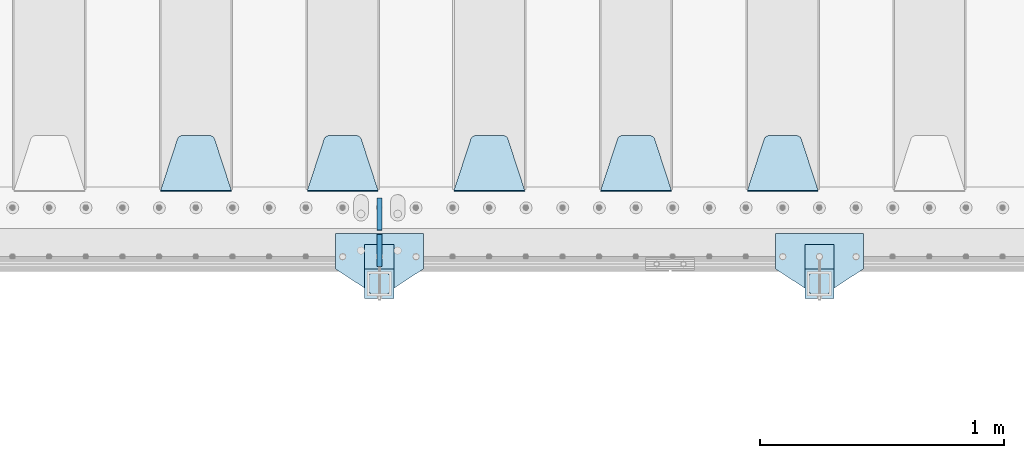
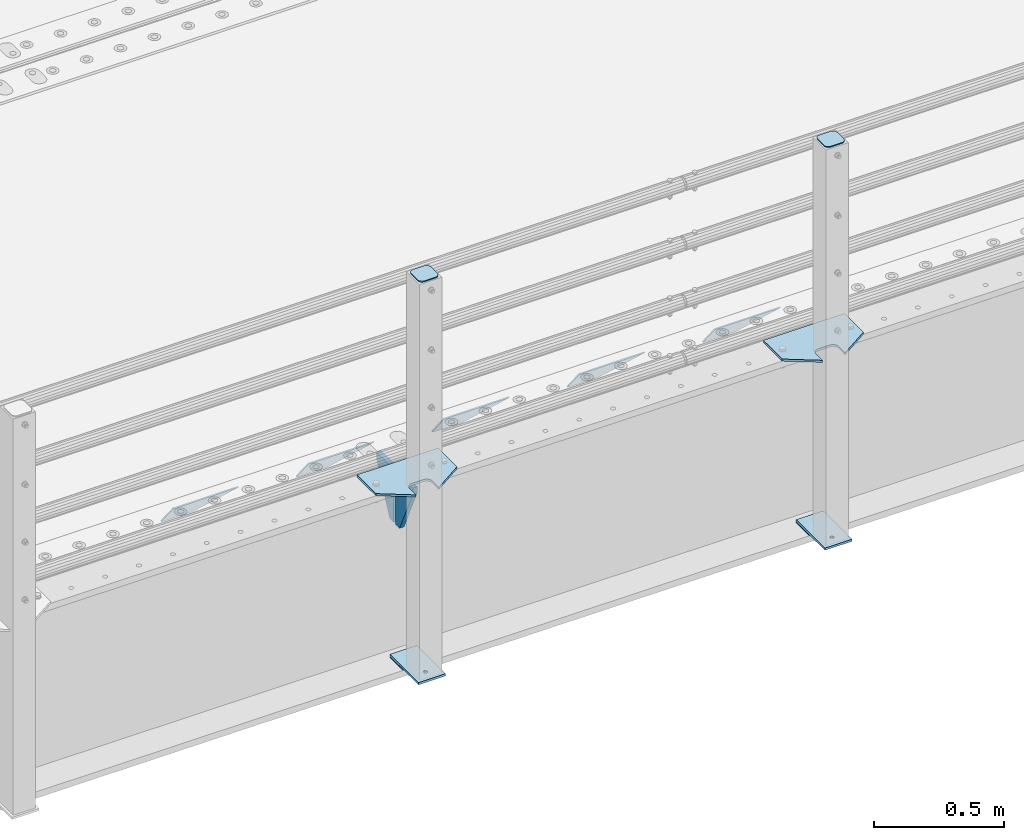
# One storey, part 176 of 219: 15 plates.
"""IFC2X3 building model written with IfcOpenShell, lengths in millimetres."""

from ifc_helpers import new_model, si_unit, frame, origin_with_axes, place, context, subcontext, project, spatial, faceted_brep, material, type_object, element, save


model = new_model("IFC2X3")

# Units and contexts
model_context = context("Model", 3, precision=1e-05, world=origin_with_axes())
body_context = subcontext(model_context, "Body", "Model", "MODEL_VIEW")
ifc_project = project(units=[si_unit("LENGTHUNIT", "METRE", prefix="MILLI"), si_unit("AREAUNIT", "SQUARE_METRE"), si_unit("VOLUMEUNIT", "CUBIC_METRE"), si_unit("MASSUNIT", "GRAM", prefix="KILO"), si_unit("TIMEUNIT", "SECOND"), si_unit("PLANEANGLEUNIT", "RADIAN"), si_unit("SOLIDANGLEUNIT", "STERADIAN"), si_unit("THERMODYNAMICTEMPERATUREUNIT", "DEGREE_CELSIUS"), si_unit("LUMINOUSINTENSITYUNIT", "LUMEN")], contexts=[model_context])

# Site, building, storey
site_placement = place(None, origin_with_axes())
site = spatial("IfcSite", under=ifc_project, at=site_placement, CompositionType="ELEMENT")
building_placement = place(site_placement, origin_with_axes())
building = spatial("IfcBuilding", under=site, at=building_placement, Name="Standard", CompositionType="ELEMENT")
storey_placement = place(building_placement, origin_with_axes())
storey = spatial("IfcBuildingStorey", under=building, at=storey_placement, Name="Undefined", CompositionType="ELEMENT", Elevation=0.0)

# Plates
ifc_material_1 = material(Name="STEEL/S355N")
plate_type_1 = type_object("IfcPlateType", PredefinedType="NOTDEFINED")
plate_1_placement = place(storey_placement, frame((5945.0, 24168.232233047, -1.76776695296758), z_axis=(0.0, 0.707106781186547, -0.707106781186548), x_axis=(-1.0, 0.0, 0.0)))
element("IfcPlate", 1, at=plate_1_placement, inside=storey, type_object=plate_type_1, material=ifc_material_1, context=body_context, shape_type="Brep", body=[
    faceted_brep([(0.0, -2.5, 0.0), (69.345504679477, -2.5, 300.171731424834), (69.345504679477, 2.49999999999636, 300.171731424831), (0.0, 2.5, 0.0), (70.9274061199576, -2.50000000000364, 304.8974424154), (70.9274061199576, 2.49999999999636, 304.8974424154), (73.3818627772307, -2.50000000000364, 309.234538108532), (73.3818627772307, 2.49999999999636, 309.234538108532), (76.6187032999569, -2.50000000000364, 313.023683126106), (76.6187032999569, 2.49999999999636, 313.023683126106), (80.5190132704993, -2.50000000000364, 316.125672595372), (80.5190132704993, 2.49999999999636, 316.125672595372), (84.9395038596831, -2.50000000000364, 318.426546230476), (84.9395038596831, 2.5, 318.426546230479), (89.7177759439237, -2.50000000000364, 319.841774983277), (89.7177759439237, 2.5, 319.841774983281), (94.6782862926502, -2.50000000000364, 320.319366455078), (94.6782862926502, 2.49999999999636, 320.319366455078), (195.32171370735, -2.50000000000364, 320.319366455078), (195.32171370735, 2.49999999999636, 320.319366455078), (200.282224056076, -2.50000000000364, 319.841774983277), (200.282224056076, 2.5, 319.841774983281), (205.060496140317, -2.50000000000364, 318.426546230476), (205.060496140317, 2.49999999999636, 318.426546230476), (209.480986729501, -2.50000000000364, 316.125672595372), (209.480986729501, 2.49999999999636, 316.125672595372), (213.381296700043, -2.50000000000364, 313.023683126106), (213.381296700043, 2.49999999999272, 313.023683126106), (216.618137222769, -2.50000000000364, 309.234538108529), (216.618137222769, 2.49999999999636, 309.234538108525), (219.072593880042, -2.50000000000364, 304.8974424154), (219.072593880042, 2.49999999999636, 304.8974424154), (220.654495320523, -2.5, 300.171731424834), (220.654495320523, 2.49999999999636, 300.171731424831), (290.0, -2.50000000000364, 3.63797880709171e-12), (290.0, 2.49999999999636, 0.0)], [[[0, 1, 2, 3]], [[1, 4, 5, 2]], [[4, 6, 7, 5]], [[6, 8, 9, 7]], [[8, 10, 11, 9]], [[10, 12, 13, 11]], [[12, 14, 15, 13]], [[14, 16, 17, 15]], [[16, 18, 19, 17]], [[18, 20, 21, 19]], [[20, 22, 23, 21]], [[22, 24, 25, 23]], [[24, 26, 27, 25]], [[26, 28, 29, 27]], [[28, 30, 31, 29]], [[30, 32, 33, 31]], [[32, 34, 35, 33]], [[34, 0, 3, 35]], [[5, 7, 9, 11, 13, 15, 17, 19, 21, 23, 25, 27, 29, 31, 33, 35, 3, 2]], [[34, 32, 30, 28, 26, 24, 22, 20, 18, 16, 14, 12, 10, 8, 6, 4, 1, 0]]]),
])
plate_2_placement = place(storey_placement, frame((5345.0, 24168.232233047, -1.76776695296758), z_axis=(0.0, 0.707106781186547, -0.707106781186548), x_axis=(-1.0, 0.0, 0.0)))
element("IfcPlate", 2, at=plate_2_placement, inside=storey, type_object=plate_type_1, material=ifc_material_1, context=body_context, shape_type="Brep", body=[
    faceted_brep([(0.0, -2.5, 0.0), (69.345504679477, -2.5, 300.171731424834), (69.345504679477, 2.49999999999636, 300.171731424831), (0.0, 2.5, 0.0), (70.9274061199576, -2.50000000000364, 304.8974424154), (70.9274061199576, 2.49999999999636, 304.8974424154), (73.3818627772307, -2.50000000000364, 309.234538108532), (73.3818627772307, 2.49999999999636, 309.234538108532), (76.6187032999569, -2.50000000000364, 313.023683126106), (76.6187032999569, 2.49999999999636, 313.023683126106), (80.5190132704993, -2.50000000000364, 316.125672595372), (80.5190132704993, 2.49999999999636, 316.125672595372), (84.9395038596831, -2.50000000000364, 318.426546230476), (84.9395038596831, 2.5, 318.426546230479), (89.7177759439237, -2.50000000000364, 319.841774983277), (89.7177759439237, 2.5, 319.841774983281), (94.6782862926502, -2.50000000000364, 320.319366455078), (94.6782862926502, 2.49999999999636, 320.319366455078), (195.32171370735, -2.50000000000364, 320.319366455078), (195.32171370735, 2.49999999999636, 320.319366455078), (200.282224056076, -2.50000000000364, 319.841774983277), (200.282224056076, 2.5, 319.841774983281), (205.060496140317, -2.50000000000364, 318.426546230476), (205.060496140317, 2.49999999999636, 318.426546230476), (209.480986729501, -2.50000000000364, 316.125672595372), (209.480986729501, 2.49999999999636, 316.125672595372), (213.381296700043, -2.50000000000364, 313.023683126106), (213.381296700043, 2.49999999999272, 313.023683126106), (216.618137222769, -2.50000000000364, 309.234538108529), (216.618137222769, 2.49999999999636, 309.234538108525), (219.072593880042, -2.50000000000364, 304.8974424154), (219.072593880042, 2.49999999999636, 304.8974424154), (220.654495320523, -2.5, 300.171731424834), (220.654495320523, 2.49999999999636, 300.171731424831), (290.0, -2.50000000000364, 3.63797880709171e-12), (290.0, 2.49999999999636, 0.0)], [[[0, 1, 2, 3]], [[1, 4, 5, 2]], [[4, 6, 7, 5]], [[6, 8, 9, 7]], [[8, 10, 11, 9]], [[10, 12, 13, 11]], [[12, 14, 15, 13]], [[14, 16, 17, 15]], [[16, 18, 19, 17]], [[18, 20, 21, 19]], [[20, 22, 23, 21]], [[22, 24, 25, 23]], [[24, 26, 27, 25]], [[26, 28, 29, 27]], [[28, 30, 31, 29]], [[30, 32, 33, 31]], [[32, 34, 35, 33]], [[34, 0, 3, 35]], [[5, 7, 9, 11, 13, 15, 17, 19, 21, 23, 25, 27, 29, 31, 33, 35, 3, 2]], [[34, 32, 30, 28, 26, 24, 22, 20, 18, 16, 14, 12, 10, 8, 6, 4, 1, 0]]]),
])
plate_3_placement = place(storey_placement, frame((4745.0, 24168.232233047, -1.76776695296758), z_axis=(0.0, 0.707106781186547, -0.707106781186548), x_axis=(-1.0, 0.0, 0.0)))
element("IfcPlate", 3, at=plate_3_placement, inside=storey, type_object=plate_type_1, material=ifc_material_1, context=body_context, shape_type="Brep", body=[
    faceted_brep([(0.0, -2.5, 0.0), (69.345504679477, -2.5, 300.171731424834), (69.345504679477, 2.49999999999636, 300.171731424831), (0.0, 2.5, 0.0), (70.9274061199576, -2.50000000000364, 304.8974424154), (70.9274061199576, 2.49999999999636, 304.8974424154), (73.3818627772307, -2.50000000000364, 309.234538108532), (73.3818627772307, 2.49999999999636, 309.234538108532), (76.6187032999569, -2.50000000000364, 313.023683126106), (76.6187032999569, 2.49999999999636, 313.023683126106), (80.5190132704993, -2.50000000000364, 316.125672595372), (80.5190132704993, 2.49999999999636, 316.125672595372), (84.9395038596831, -2.50000000000364, 318.426546230476), (84.9395038596831, 2.5, 318.426546230479), (89.7177759439237, -2.50000000000364, 319.841774983277), (89.7177759439237, 2.5, 319.841774983281), (94.6782862926502, -2.50000000000364, 320.319366455078), (94.6782862926502, 2.49999999999636, 320.319366455078), (195.32171370735, -2.50000000000364, 320.319366455078), (195.32171370735, 2.49999999999636, 320.319366455078), (200.282224056076, -2.50000000000364, 319.841774983277), (200.282224056076, 2.5, 319.841774983281), (205.060496140317, -2.50000000000364, 318.426546230476), (205.060496140317, 2.49999999999636, 318.426546230476), (209.480986729501, -2.50000000000364, 316.125672595372), (209.480986729501, 2.49999999999636, 316.125672595372), (213.381296700043, -2.50000000000364, 313.023683126106), (213.381296700043, 2.49999999999272, 313.023683126106), (216.618137222769, -2.50000000000364, 309.234538108529), (216.618137222769, 2.49999999999636, 309.234538108525), (219.072593880042, -2.50000000000364, 304.8974424154), (219.072593880042, 2.49999999999636, 304.8974424154), (220.654495320523, -2.5, 300.171731424834), (220.654495320523, 2.49999999999636, 300.171731424831), (290.0, -2.50000000000364, 3.63797880709171e-12), (290.0, 2.49999999999636, 0.0)], [[[0, 1, 2, 3]], [[1, 4, 5, 2]], [[4, 6, 7, 5]], [[6, 8, 9, 7]], [[8, 10, 11, 9]], [[10, 12, 13, 11]], [[12, 14, 15, 13]], [[14, 16, 17, 15]], [[16, 18, 19, 17]], [[18, 20, 21, 19]], [[20, 22, 23, 21]], [[22, 24, 25, 23]], [[24, 26, 27, 25]], [[26, 28, 29, 27]], [[28, 30, 31, 29]], [[30, 32, 33, 31]], [[32, 34, 35, 33]], [[34, 0, 3, 35]], [[5, 7, 9, 11, 13, 15, 17, 19, 21, 23, 25, 27, 29, 31, 33, 35, 3, 2]], [[34, 32, 30, 28, 26, 24, 22, 20, 18, 16, 14, 12, 10, 8, 6, 4, 1, 0]]]),
])
plate_4_placement = place(storey_placement, frame((4145.0, 24168.232233047, -1.76776695296758), z_axis=(0.0, 0.707106781186547, -0.707106781186548), x_axis=(-1.0, 0.0, 0.0)))
element("IfcPlate", 4, at=plate_4_placement, inside=storey, type_object=plate_type_1, material=ifc_material_1, context=body_context, shape_type="Brep", body=[
    faceted_brep([(0.0, -2.5, 0.0), (69.345504679477, -2.5, 300.171731424834), (69.345504679477, 2.49999999999636, 300.171731424831), (0.0, 2.5, 0.0), (70.9274061199576, -2.50000000000364, 304.8974424154), (70.9274061199576, 2.49999999999636, 304.8974424154), (73.3818627772307, -2.50000000000364, 309.234538108532), (73.3818627772307, 2.49999999999636, 309.234538108532), (76.6187032999569, -2.50000000000364, 313.023683126106), (76.6187032999569, 2.49999999999636, 313.023683126106), (80.5190132704993, -2.50000000000364, 316.125672595372), (80.5190132704993, 2.49999999999636, 316.125672595372), (84.9395038596831, -2.50000000000364, 318.426546230476), (84.9395038596831, 2.5, 318.426546230479), (89.7177759439237, -2.50000000000364, 319.841774983277), (89.7177759439237, 2.5, 319.841774983281), (94.6782862926502, -2.50000000000364, 320.319366455078), (94.6782862926502, 2.49999999999636, 320.319366455078), (195.32171370735, -2.50000000000364, 320.319366455078), (195.32171370735, 2.49999999999636, 320.319366455078), (200.282224056076, -2.50000000000364, 319.841774983277), (200.282224056076, 2.5, 319.841774983281), (205.060496140317, -2.50000000000364, 318.426546230476), (205.060496140317, 2.49999999999636, 318.426546230476), (209.480986729501, -2.50000000000364, 316.125672595372), (209.480986729501, 2.49999999999636, 316.125672595372), (213.381296700043, -2.50000000000364, 313.023683126106), (213.381296700043, 2.49999999999272, 313.023683126106), (216.618137222769, -2.50000000000364, 309.234538108529), (216.618137222769, 2.49999999999636, 309.234538108525), (219.072593880042, -2.50000000000364, 304.8974424154), (219.072593880042, 2.49999999999636, 304.8974424154), (220.654495320523, -2.5, 300.171731424834), (220.654495320523, 2.49999999999636, 300.171731424831), (290.0, -2.50000000000364, 3.63797880709171e-12), (290.0, 2.49999999999636, 0.0)], [[[0, 1, 2, 3]], [[1, 4, 5, 2]], [[4, 6, 7, 5]], [[6, 8, 9, 7]], [[8, 10, 11, 9]], [[10, 12, 13, 11]], [[12, 14, 15, 13]], [[14, 16, 17, 15]], [[16, 18, 19, 17]], [[18, 20, 21, 19]], [[20, 22, 23, 21]], [[22, 24, 25, 23]], [[24, 26, 27, 25]], [[26, 28, 29, 27]], [[28, 30, 31, 29]], [[30, 32, 33, 31]], [[32, 34, 35, 33]], [[34, 0, 3, 35]], [[5, 7, 9, 11, 13, 15, 17, 19, 21, 23, 25, 27, 29, 31, 33, 35, 3, 2]], [[34, 32, 30, 28, 26, 24, 22, 20, 18, 16, 14, 12, 10, 8, 6, 4, 1, 0]]]),
])
plate_5_placement = place(storey_placement, frame((3545.0, 24168.232233047, -1.76776695296758), z_axis=(0.0, 0.707106781186547, -0.707106781186548), x_axis=(-1.0, 0.0, 0.0)))
element("IfcPlate", 5, at=plate_5_placement, inside=storey, type_object=plate_type_1, material=ifc_material_1, context=body_context, shape_type="Brep", body=[
    faceted_brep([(0.0, -2.5, 0.0), (69.345504679477, -2.5, 300.171731424834), (69.345504679477, 2.49999999999636, 300.171731424831), (0.0, 2.5, 0.0), (70.9274061199576, -2.50000000000364, 304.8974424154), (70.9274061199576, 2.49999999999636, 304.8974424154), (73.3818627772307, -2.50000000000364, 309.234538108532), (73.3818627772307, 2.49999999999636, 309.234538108532), (76.6187032999569, -2.50000000000364, 313.023683126106), (76.6187032999569, 2.49999999999636, 313.023683126106), (80.5190132704993, -2.50000000000364, 316.125672595372), (80.5190132704993, 2.49999999999636, 316.125672595372), (84.9395038596831, -2.50000000000364, 318.426546230476), (84.9395038596831, 2.5, 318.426546230479), (89.7177759439237, -2.50000000000364, 319.841774983277), (89.7177759439237, 2.5, 319.841774983281), (94.6782862926502, -2.50000000000364, 320.319366455078), (94.6782862926502, 2.49999999999636, 320.319366455078), (195.32171370735, -2.50000000000364, 320.319366455078), (195.32171370735, 2.49999999999636, 320.319366455078), (200.282224056076, -2.50000000000364, 319.841774983277), (200.282224056076, 2.5, 319.841774983281), (205.060496140317, -2.50000000000364, 318.426546230476), (205.060496140317, 2.49999999999636, 318.426546230476), (209.480986729501, -2.50000000000364, 316.125672595372), (209.480986729501, 2.49999999999636, 316.125672595372), (213.381296700043, -2.50000000000364, 313.023683126106), (213.381296700043, 2.49999999999272, 313.023683126106), (216.618137222769, -2.50000000000364, 309.234538108529), (216.618137222769, 2.49999999999636, 309.234538108525), (219.072593880042, -2.50000000000364, 304.8974424154), (219.072593880042, 2.49999999999636, 304.8974424154), (220.654495320523, -2.5, 300.171731424834), (220.654495320523, 2.49999999999636, 300.171731424831), (290.0, -2.50000000000364, 3.63797880709171e-12), (290.0, 2.49999999999636, 0.0)], [[[0, 1, 2, 3]], [[1, 4, 5, 2]], [[4, 6, 7, 5]], [[6, 8, 9, 7]], [[8, 10, 11, 9]], [[10, 12, 13, 11]], [[12, 14, 15, 13]], [[14, 16, 17, 15]], [[16, 18, 19, 17]], [[18, 20, 21, 19]], [[20, 22, 23, 21]], [[22, 24, 25, 23]], [[24, 26, 27, 25]], [[26, 28, 29, 27]], [[28, 30, 31, 29]], [[30, 32, 33, 31]], [[32, 34, 35, 33]], [[34, 0, 3, 35]], [[5, 7, 9, 11, 13, 15, 17, 19, 21, 23, 25, 27, 29, 31, 33, 35, 3, 2]], [[34, 32, 30, 28, 26, 24, 22, 20, 18, 16, 14, 12, 10, 8, 6, 4, 1, 0]]]),
])
plate_type_2 = type_object("IfcPlateType", PredefinedType="NOTDEFINED")
for number, where, z_axis, x_axis in (
    (6, (4150.0, 23860.0, -30.0), (0.0, 0.0, -1.0), (0.0, 1.0, 0.0)),
    (7, (4150.0, 24140.0, -30.0), (0.0, 0.0, -1.0), (0.0, -1.0, 0.0)),
):
    element("IfcPlate", number, at=place(storey_placement, frame(where, z_axis=z_axis, x_axis=x_axis)), inside=storey, type_object=plate_type_2, material=ifc_material_1, context=body_context, shape_type="Brep", body=[
        faceted_brep([(0.0, -10.0, 0.0), (0.0, -10.0, 30.0), (0.0, 10.0, 30.0), (0.0, 10.0, 0.0), (102.0, -10.0, 250.0), (102.0, 10.0, 250.0), (132.0, -10.0, 250.0), (132.0, 10.0, 250.0), (132.0, -10.0, 30.0), (132.0, 10.0, 30.0), (131.544232590368, -10.0, 24.790554669992), (131.544232590368, 10.0, 24.790554669992), (130.190778623579, -10.0, 19.7393957002299), (130.190778623579, 10.0, 19.7393957002299), (127.980762113533, -10.0, 15.0), (127.980762113533, 10.0, 15.0), (124.98133329357, -10.0, 10.7163717094038), (124.98133329357, 10.0, 10.7163717094038), (121.283628290596, -10.0, 7.01866670643062), (121.283628290596, 10.0, 7.01866670643062), (117.0, -10.0, 4.01923788646684), (117.0, 10.0, 4.01923788646684), (112.260604299769, -10.0, 1.80922137642278), (112.260604299769, 10.0, 1.80922137642278), (107.209445330009, -10.0, 0.455767409633722), (107.209445330009, 10.0, 0.455767409633722), (102.0, -10.0, 0.0), (102.0, 10.0, 0.0)], [[[0, 1, 2, 3]], [[1, 4, 5, 2]], [[4, 6, 7, 5]], [[6, 8, 9, 7]], [[8, 10, 11, 9]], [[10, 12, 13, 11]], [[12, 14, 15, 13]], [[14, 16, 17, 15]], [[16, 18, 19, 17]], [[18, 20, 21, 19]], [[20, 22, 23, 21]], [[22, 24, 25, 23]], [[24, 26, 27, 25]], [[26, 0, 3, 27]], [[5, 7, 9, 11, 13, 15, 17, 19, 21, 23, 25, 27, 3, 2]], [[26, 24, 22, 20, 18, 16, 14, 12, 10, 8, 6, 4, 1, 0]]]),
    ])
ifc_material_2 = material(Name="STEEL/S355J2")
plate_type_3 = type_object("IfcPlateType", PredefinedType="NOTDEFINED")
plate_6_placement = place(storey_placement, frame((6130.0, 23995.0, 5.00000000004911), z_axis=(0.0, -1.0, 0.0), x_axis=(-1.0, 0.0, 0.0)))
element("IfcPlate", 8, at=plate_6_placement, inside=storey, type_object=plate_type_3, material=ifc_material_2, context=body_context, shape_type="Brep", body=[
    faceted_brep([(0.0, -5.0, 0.0), (2.31396552408114e-06, -5.0, 145.0), (2.31396552408114e-06, 5.0, 145.0), (0.0, 5.0, 0.0), (130.0, -5.0, 230.0), (130.0, 5.0, 230.0), (130.0, -5.0, 180.0), (130.0, 5.0, 180.0), (130.48036798992, -5.0, 175.122741949599), (130.48036798992, 5.0, 175.122741949599), (131.903011687218, -5.0, 170.432914190875), (131.903011687218, 5.0, 170.432914190875), (134.213259692437, -5.0, 166.110744174512), (134.213259692437, 5.0, 166.110744174512), (137.322330470337, -5.0, 162.322330470335), (137.322330470337, 5.0, 162.322330470335), (141.11074417451, -5.0, 159.213259692435), (141.11074417451, 5.0, 159.213259692435), (145.432914190873, -5.0, 156.903011687216), (145.432914190873, 5.0, 156.903011687216), (150.122741949597, -5.0, 155.48036798992), (150.122741949597, 5.0, 155.48036798992), (155.0, -5.0, 155.0), (155.0, 5.0, 155.0), (205.0, -5.0, 155.0), (205.0, 5.0, 155.0), (209.877258050403, -5.0, 155.48036798992), (209.877258050403, 5.0, 155.48036798992), (214.567085809127, -5.0, 156.903011687216), (214.567085809127, 5.0, 156.903011687216), (218.88925582549, -5.0, 159.213259692435), (218.88925582549, 5.0, 159.213259692435), (222.677669529663, -5.0, 162.322330470335), (222.677669529663, 5.0, 162.322330470335), (225.786740307563, -5.0, 166.110744174512), (225.786740307563, 5.0, 166.110744174512), (228.096988312782, -5.0, 170.432914190875), (228.096988312782, 5.0, 170.432914190875), (229.51963201008, -5.0, 175.122741949599), (229.51963201008, 5.0, 175.122741949599), (230.0, -5.0, 180.0), (230.0, 5.0, 180.0), (230.0, -5.0, 230.0), (230.0, 5.0, 230.0), (360.0, -5.0, 145.0), (360.0, 5.0, 145.0), (360.0, -5.0, -7.27595761418343e-12), (360.0, 5.0, -7.27595761418343e-12)], [[[0, 1, 2, 3]], [[1, 4, 5, 2]], [[4, 6, 7, 5]], [[6, 8, 9, 7]], [[8, 10, 11, 9]], [[10, 12, 13, 11]], [[12, 14, 15, 13]], [[14, 16, 17, 15]], [[16, 18, 19, 17]], [[18, 20, 21, 19]], [[20, 22, 23, 21]], [[22, 24, 25, 23]], [[24, 26, 27, 25]], [[26, 28, 29, 27]], [[28, 30, 31, 29]], [[30, 32, 33, 31]], [[32, 34, 35, 33]], [[34, 36, 37, 35]], [[36, 38, 39, 37]], [[38, 40, 41, 39]], [[40, 42, 43, 41]], [[42, 44, 45, 43]], [[44, 46, 47, 45]], [[46, 0, 3, 47]], [[5, 7, 9, 11, 13, 15, 17, 19, 21, 23, 25, 27, 29, 31, 33, 35, 37, 39, 41, 43, 45, 47, 3, 2]], [[46, 44, 42, 40, 38, 36, 34, 32, 30, 28, 26, 24, 22, 20, 18, 16, 14, 12, 10, 8, 6, 4, 1, 0]]]),
])
plate_7_placement = place(storey_placement, frame((4330.0, 23995.0, 5.00000000004911), z_axis=(0.0, -1.0, 0.0), x_axis=(-1.0, 0.0, 0.0)))
element("IfcPlate", 9, at=plate_7_placement, inside=storey, type_object=plate_type_3, material=ifc_material_2, context=body_context, shape_type="Brep", body=[
    faceted_brep([(0.0, -5.0, 0.0), (2.31396552408114e-06, -5.0, 145.0), (2.31396552408114e-06, 5.0, 145.0), (0.0, 5.0, 0.0), (130.0, -5.0, 230.0), (130.0, 5.0, 230.0), (130.0, -5.0, 180.0), (130.0, 5.0, 180.0), (130.48036798992, -5.0, 175.122741949599), (130.48036798992, 5.0, 175.122741949599), (131.903011687218, -5.0, 170.432914190875), (131.903011687218, 5.0, 170.432914190875), (134.213259692437, -5.0, 166.110744174512), (134.213259692437, 5.0, 166.110744174512), (137.322330470337, -5.0, 162.322330470335), (137.322330470337, 5.0, 162.322330470335), (141.11074417451, -5.0, 159.213259692435), (141.11074417451, 5.0, 159.213259692435), (145.432914190873, -5.0, 156.903011687216), (145.432914190873, 5.0, 156.903011687216), (150.122741949597, -5.0, 155.48036798992), (150.122741949597, 5.0, 155.48036798992), (155.0, -5.0, 155.0), (155.0, 5.0, 155.0), (205.0, -5.0, 155.0), (205.0, 5.0, 155.0), (209.877258050403, -5.0, 155.48036798992), (209.877258050403, 5.0, 155.48036798992), (214.567085809127, -5.0, 156.903011687216), (214.567085809127, 5.0, 156.903011687216), (218.88925582549, -5.0, 159.213259692435), (218.88925582549, 5.0, 159.213259692435), (222.677669529663, -5.0, 162.322330470335), (222.677669529663, 5.0, 162.322330470335), (225.786740307563, -5.0, 166.110744174512), (225.786740307563, 5.0, 166.110744174512), (228.096988312782, -5.0, 170.432914190875), (228.096988312782, 5.0, 170.432914190875), (229.51963201008, -5.0, 175.122741949599), (229.51963201008, 5.0, 175.122741949599), (230.0, -5.0, 180.0), (230.0, 5.0, 180.0), (230.0, -5.0, 230.0), (230.0, 5.0, 230.0), (360.0, -5.0, 145.0), (360.0, 5.0, 145.0), (360.0, -5.0, -7.27595761418343e-12), (360.0, 5.0, -7.27595761418343e-12)], [[[0, 1, 2, 3]], [[1, 4, 5, 2]], [[4, 6, 7, 5]], [[6, 8, 9, 7]], [[8, 10, 11, 9]], [[10, 12, 13, 11]], [[12, 14, 15, 13]], [[14, 16, 17, 15]], [[16, 18, 19, 17]], [[18, 20, 21, 19]], [[20, 22, 23, 21]], [[22, 24, 25, 23]], [[24, 26, 27, 25]], [[26, 28, 29, 27]], [[28, 30, 31, 29]], [[30, 32, 33, 31]], [[32, 34, 35, 33]], [[34, 36, 37, 35]], [[36, 38, 39, 37]], [[38, 40, 41, 39]], [[40, 42, 43, 41]], [[42, 44, 45, 43]], [[44, 46, 47, 45]], [[46, 0, 3, 47]], [[5, 7, 9, 11, 13, 15, 17, 19, 21, 23, 25, 27, 29, 31, 33, 35, 37, 39, 41, 43, 45, 47, 3, 2]], [[46, 44, 42, 40, 38, 36, 34, 32, 30, 28, 26, 24, 22, 20, 18, 16, 14, 12, 10, 8, 6, 4, 1, 0]]]),
])
plate_type_4 = type_object("IfcPlateType", PredefinedType="NOTDEFINED")
for number, where, z_axis, x_axis in (
    (10, (6009.99999999986, 23949.9999999998, -850.000000000002), (0.0, -1.0, 0.0), (-1.0, 0.0, 0.0)),
    (11, (4209.99999999986, 23949.9999999998, -850.000000000002), (0.0, -1.0, 0.0), (-1.0, 0.0, 0.0)),
):
    element("IfcPlate", number, at=place(storey_placement, frame(where, z_axis=z_axis, x_axis=x_axis)), inside=storey, type_object=plate_type_4, material=ifc_material_2, context=body_context, shape_type="Brep", body=[
        faceted_brep([(53.6360389691836, -5.0, 176.363961030467), (53.6360389691836, 5.0, 176.363961030467), (59.9999999998618, 5.0, 178.999999999789), (59.9999999998618, -5.0, 178.999999999789), (66.3639610305399, 5.0, 176.363961030467), (66.3639610305399, -5.0, 176.363961030467), (68.9999999998618, 5.0, 169.999999999789), (68.9999999998618, -5.0, 169.999999999789), (66.3639610305399, 5.0, 163.636038969111), (66.3639610305399, -5.0, 163.636038969111), (59.9999999998618, 5.0, 160.999999999789), (59.9999999998618, -5.0, 160.999999999789), (53.6360389691836, 5.0, 163.636038969111), (53.6360389691836, -5.0, 163.636038969111), (50.9999999998618, 5.0, 169.999999999789), (50.9999999998618, -5.0, 169.999999999789), (120.0, -5.0, 0.0), (120.0, -5.0, 220.0), (0.0, -5.0, 220.0), (0.0, -5.0, 0.0), (0.0, 5.0, 0.0), (120.0, 5.0, 0.0), (120.0, 5.0, 220.0), (0.0, 5.0, 220.0)], [[[0, 1, 2, 3]], [[3, 2, 4, 5]], [[5, 4, 6, 7]], [[7, 6, 8, 9]], [[9, 8, 10, 11]], [[11, 10, 12, 13]], [[13, 12, 14, 15]], [[15, 14, 1, 0]], [[16, 17, 18, 19], [11, 13, 15, 0, 3, 5, 7, 9]], [[16, 19, 20, 21]], [[17, 16, 21, 22]], [[18, 17, 22, 23]], [[19, 18, 23, 20]], [[22, 21, 20, 23], [2, 1, 14, 12, 10, 8, 6, 4]]]),
    ])
plate_type_5 = type_object("IfcPlateType", PredefinedType="NOTDEFINED")
plate_8_placement = place(storey_placement, frame((5905.99999999987, 23833.9999999998, 1012.50000000001), z_axis=(0.0, -1.0, 0.0), x_axis=(1.0, 0.0, 0.0)))
element("IfcPlate", 12, at=plate_8_placement, inside=storey, type_object=plate_type_5, material=ifc_material_2, context=body_context, shape_type="Brep", body=[
    faceted_brep([(0.0, -2.5, 19.0), (0.0, -2.5, 69.0), (0.0, 2.5, 69.0), (0.0, 2.5, 19.0), (0.476369668545885, -2.5, 73.2278977451715), (0.476369668545885, 2.5, 73.2278977451715), (1.88159150985484, -2.5, 77.2437910432345), (1.88159150985484, 2.5, 77.2437910432345), (4.14520183310742, -2.5, 80.8463062353185), (4.14520183310742, 2.5, 80.8463062353185), (7.15369376468334, -2.5, 83.8547981668889), (7.15369376468334, 2.5, 83.8547981668889), (10.7562089567673, -2.5, 86.118408490147), (10.7562089567673, 2.5, 86.118408490147), (14.7721022548303, -2.5, 87.5236303314523), (14.7721022548303, 2.5, 87.5236303314523), (19.0, -2.5, 88.0), (19.0, 2.5, 88.0), (69.0, -2.5, 88.0), (69.0, 2.5, 88.0), (73.2278977451697, -2.5, 87.5236303314523), (73.2278977451697, 2.5, 87.5236303314523), (77.2437910432327, -2.5, 86.118408490147), (77.2437910432327, 2.5, 86.118408490147), (80.8463062353167, -2.5, 83.8547981668889), (80.8463062353167, 2.5, 83.8547981668889), (83.8547981668926, -2.5, 80.8463062353185), (83.8547981668926, 2.5, 80.8463062353185), (86.1184084901452, -2.5, 77.2437910432345), (86.1184084901452, 2.5, 77.2437910432345), (87.5236303314541, -2.5, 73.2278977451715), (87.5236303314541, 2.5, 73.2278977451715), (88.0, -2.5, 69.0), (88.0, 2.5, 69.0), (88.0, -2.5, 19.0), (88.0, 2.5, 19.0), (87.5236303314541, -2.5, 14.7721022548285), (87.5236303314541, 2.5, 14.7721022548285), (86.1184084901452, -2.5, 10.7562089567655), (86.1184084901452, 2.5, 10.7562089567655), (83.8547981668926, -2.5, 7.15369376468152), (83.8547981668926, 2.5, 7.15369376468152), (80.8463062353167, -2.5, 4.14520183311106), (80.8463062353167, 2.5, 4.14520183311106), (77.2437910432345, -2.5, 1.88159150985302), (77.2437910432345, 2.5, 1.88159150985302), (73.2278977451697, -2.5, 0.476369668547704), (73.2278977451697, 2.5, 0.476369668547704), (69.0, -2.5, 0.0), (69.0, 2.5, 0.0), (19.0, -2.5, 0.0), (19.0, 2.5, 0.0), (14.7721022548303, -2.5, 0.476369668547704), (14.7721022548303, 2.5, 0.476369668547704), (10.7562089567673, -2.5, 1.88159150985302), (10.7562089567673, 2.5, 1.88159150985302), (7.15369376468334, -2.5, 4.14520183311106), (7.15369376468334, 2.5, 4.14520183311106), (4.14520183310742, -2.5, 7.15369376468152), (4.14520183310742, 2.5, 7.15369376468152), (1.88159150985484, -2.5, 10.7562089567655), (1.88159150985484, 2.5, 10.7562089567655), (0.476369668545885, -2.5, 14.7721022548285), (0.476369668545885, 2.5, 14.7721022548285)], [[[0, 1, 2, 3]], [[1, 4, 5, 2]], [[4, 6, 7, 5]], [[6, 8, 9, 7]], [[8, 10, 11, 9]], [[10, 12, 13, 11]], [[12, 14, 15, 13]], [[14, 16, 17, 15]], [[16, 18, 19, 17]], [[18, 20, 21, 19]], [[20, 22, 23, 21]], [[22, 24, 25, 23]], [[24, 26, 27, 25]], [[26, 28, 29, 27]], [[28, 30, 31, 29]], [[30, 32, 33, 31]], [[32, 34, 35, 33]], [[34, 36, 37, 35]], [[36, 38, 39, 37]], [[38, 40, 41, 39]], [[40, 42, 43, 41]], [[42, 44, 45, 43]], [[44, 46, 47, 45]], [[46, 48, 49, 47]], [[48, 50, 51, 49]], [[50, 52, 53, 51]], [[52, 54, 55, 53]], [[54, 56, 57, 55]], [[56, 58, 59, 57]], [[58, 60, 61, 59]], [[60, 62, 63, 61]], [[62, 0, 3, 63]], [[5, 7, 9, 11, 13, 15, 17, 19, 21, 23, 25, 27, 29, 31, 33, 35, 37, 39, 41, 43, 45, 47, 49, 51, 53, 55, 57, 59, 61, 63, 3, 2]], [[62, 60, 58, 56, 54, 52, 50, 48, 46, 44, 42, 40, 38, 36, 34, 32, 30, 28, 26, 24, 22, 20, 18, 16, 14, 12, 10, 8, 6, 4, 1, 0]]]),
])
plate_9_placement = place(storey_placement, frame((4105.99999999987, 23833.9999999998, 1012.50000000001), z_axis=(0.0, -1.0, 0.0), x_axis=(1.0, 0.0, 0.0)))
element("IfcPlate", 13, at=plate_9_placement, inside=storey, type_object=plate_type_5, material=ifc_material_2, context=body_context, shape_type="Brep", body=[
    faceted_brep([(0.0, -2.5, 19.0), (0.0, -2.5, 69.0), (0.0, 2.5, 69.0), (0.0, 2.5, 19.0), (0.476369668545885, -2.5, 73.2278977451715), (0.476369668545885, 2.5, 73.2278977451715), (1.88159150985484, -2.5, 77.2437910432345), (1.88159150985484, 2.5, 77.2437910432345), (4.14520183310742, -2.5, 80.8463062353185), (4.14520183310742, 2.5, 80.8463062353185), (7.15369376468334, -2.5, 83.8547981668889), (7.15369376468334, 2.5, 83.8547981668889), (10.7562089567673, -2.5, 86.118408490147), (10.7562089567673, 2.5, 86.118408490147), (14.7721022548303, -2.5, 87.5236303314523), (14.7721022548303, 2.5, 87.5236303314523), (19.0, -2.5, 88.0), (19.0, 2.5, 88.0), (69.0, -2.5, 88.0), (69.0, 2.5, 88.0), (73.2278977451697, -2.5, 87.5236303314523), (73.2278977451697, 2.5, 87.5236303314523), (77.2437910432327, -2.5, 86.118408490147), (77.2437910432327, 2.5, 86.118408490147), (80.8463062353167, -2.5, 83.8547981668889), (80.8463062353167, 2.5, 83.8547981668889), (83.8547981668926, -2.5, 80.8463062353185), (83.8547981668926, 2.5, 80.8463062353185), (86.1184084901452, -2.5, 77.2437910432345), (86.1184084901452, 2.5, 77.2437910432345), (87.5236303314541, -2.5, 73.2278977451715), (87.5236303314541, 2.5, 73.2278977451715), (88.0, -2.5, 69.0), (88.0, 2.5, 69.0), (88.0, -2.5, 19.0), (88.0, 2.5, 19.0), (87.5236303314541, -2.5, 14.7721022548285), (87.5236303314541, 2.5, 14.7721022548285), (86.1184084901452, -2.5, 10.7562089567655), (86.1184084901452, 2.5, 10.7562089567655), (83.8547981668926, -2.5, 7.15369376468152), (83.8547981668926, 2.5, 7.15369376468152), (80.8463062353167, -2.5, 4.14520183311106), (80.8463062353167, 2.5, 4.14520183311106), (77.2437910432345, -2.5, 1.88159150985302), (77.2437910432345, 2.5, 1.88159150985302), (73.2278977451697, -2.5, 0.476369668547704), (73.2278977451697, 2.5, 0.476369668547704), (69.0, -2.5, 0.0), (69.0, 2.5, 0.0), (19.0, -2.5, 0.0), (19.0, 2.5, 0.0), (14.7721022548303, -2.5, 0.476369668547704), (14.7721022548303, 2.5, 0.476369668547704), (10.7562089567673, -2.5, 1.88159150985302), (10.7562089567673, 2.5, 1.88159150985302), (7.15369376468334, -2.5, 4.14520183311106), (7.15369376468334, 2.5, 4.14520183311106), (4.14520183310742, -2.5, 7.15369376468152), (4.14520183310742, 2.5, 7.15369376468152), (1.88159150985484, -2.5, 10.7562089567655), (1.88159150985484, 2.5, 10.7562089567655), (0.476369668545885, -2.5, 14.7721022548285), (0.476369668545885, 2.5, 14.7721022548285)], [[[0, 1, 2, 3]], [[1, 4, 5, 2]], [[4, 6, 7, 5]], [[6, 8, 9, 7]], [[8, 10, 11, 9]], [[10, 12, 13, 11]], [[12, 14, 15, 13]], [[14, 16, 17, 15]], [[16, 18, 19, 17]], [[18, 20, 21, 19]], [[20, 22, 23, 21]], [[22, 24, 25, 23]], [[24, 26, 27, 25]], [[26, 28, 29, 27]], [[28, 30, 31, 29]], [[30, 32, 33, 31]], [[32, 34, 35, 33]], [[34, 36, 37, 35]], [[36, 38, 39, 37]], [[38, 40, 41, 39]], [[40, 42, 43, 41]], [[42, 44, 45, 43]], [[44, 46, 47, 45]], [[46, 48, 49, 47]], [[48, 50, 51, 49]], [[50, 52, 53, 51]], [[52, 54, 55, 53]], [[54, 56, 57, 55]], [[56, 58, 59, 57]], [[58, 60, 61, 59]], [[60, 62, 63, 61]], [[62, 0, 3, 63]], [[5, 7, 9, 11, 13, 15, 17, 19, 21, 23, 25, 27, 29, 31, 33, 35, 37, 39, 41, 43, 45, 47, 49, 51, 53, 55, 57, 59, 61, 63, 3, 2]], [[62, 60, 58, 56, 54, 52, 50, 48, 46, 44, 42, 40, 38, 36, 34, 32, 30, 28, 26, 24, 22, 20, 18, 16, 14, 12, 10, 8, 6, 4, 1, 0]]]),
])
plate_type_6 = type_object("IfcPlateType", PredefinedType="NOTDEFINED")
for number, where, z_axis, x_axis in (
    (14, (6009.99999999986, 23949.9999999998, -857.500000000002), (0.0, -1.0, 0.0), (-1.0, 0.0, 0.0)),
    (15, (4209.99999999986, 23949.9999999998, -857.500000000002), (0.0, -1.0, 0.0), (-1.0, 0.0, 0.0)),
):
    element("IfcPlate", number, at=place(storey_placement, frame(where, z_axis=z_axis, x_axis=x_axis)), inside=storey, type_object=plate_type_6, material=ifc_material_2, context=body_context, shape_type="Brep", body=[
        faceted_brep([(0.0, -2.5, 0.0), (0.0, -2.5, 100.0), (0.0, 2.5, 100.0), (0.0, 2.5, 0.0), (120.0, -2.5, 100.0), (120.0, 2.5, 100.0), (120.0, -2.5, 0.0), (120.0, 2.5, 0.0)], [[[0, 1, 2, 3]], [[1, 4, 5, 2]], [[4, 6, 7, 5]], [[6, 0, 3, 7]], [[5, 7, 3, 2]], [[6, 4, 1, 0]]]),
    ])

save(model, "model.ifc")
